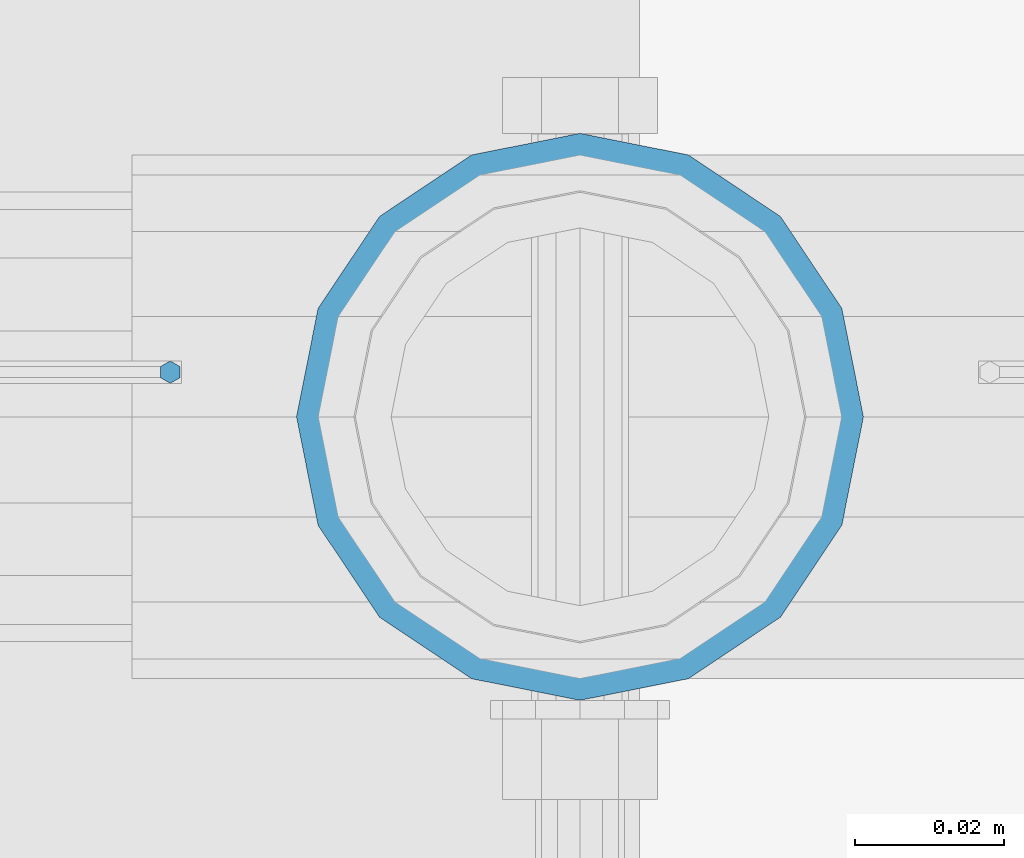
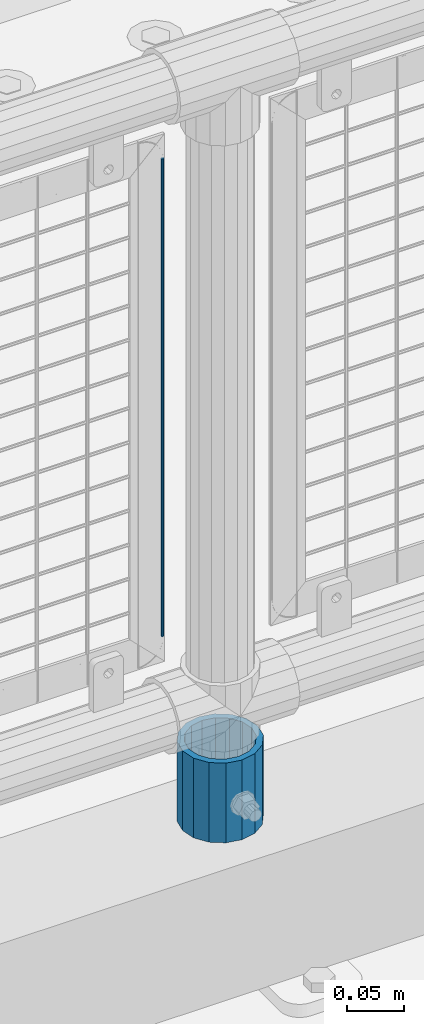
# One storey, part 90 of 242: 2 columns.
"""IFC2X3 building model written with IfcOpenShell, lengths in millimetres."""

from ifc_helpers import new_model, si_unit, frame, origin_with_axes, place, context, subcontext, project, spatial, faceted_brep, material, type_object, element, save


model = new_model("IFC2X3")

# Units and contexts
model_context = context("Model", 3, precision=1e-05, world=origin_with_axes())
body_context = subcontext(model_context, "Body", "Model", "MODEL_VIEW")
ifc_project = project(units=[si_unit("LENGTHUNIT", "METRE", prefix="MILLI"), si_unit("AREAUNIT", "SQUARE_METRE"), si_unit("VOLUMEUNIT", "CUBIC_METRE"), si_unit("MASSUNIT", "GRAM", prefix="KILO"), si_unit("TIMEUNIT", "SECOND"), si_unit("PLANEANGLEUNIT", "RADIAN"), si_unit("SOLIDANGLEUNIT", "STERADIAN"), si_unit("THERMODYNAMICTEMPERATUREUNIT", "DEGREE_CELSIUS"), si_unit("LUMINOUSINTENSITYUNIT", "LUMEN")], contexts=[model_context])

# Site, building, storey
site_placement = place(None, origin_with_axes())
site = spatial("IfcSite", under=ifc_project, at=site_placement, CompositionType="ELEMENT")
building_placement = place(site_placement, origin_with_axes())
building = spatial("IfcBuilding", under=site, at=building_placement, Name="Standard", CompositionType="ELEMENT")
storey_placement = place(building_placement, origin_with_axes())
storey = spatial("IfcBuildingStorey", under=building, at=storey_placement, Name="Undefined", CompositionType="ELEMENT", Elevation=0.0)

# Columns
ifc_material_1 = material(Name="Misc_Undefined")
column_type_1 = type_object("IfcColumnType", Name="D3", PredefinedType="NOTDEFINED")
column_1_placement = place(storey_placement, frame((-30453.0, -19329.5, 378.02), z_axis=(-1.0, 0.0, 0.0), x_axis=(0.0, 0.0, 1.0)))
element("IfcColumn", 1, at=column_1_placement, inside=storey, type_object=column_type_1, material=ifc_material_1, ObjectType="D3", context=body_context, shape_type="Brep", body=[
    faceted_brep([(0.0, -1.50000000000364, 0.0), (-3.63797880709171e-12, -0.750000000003638, -1.29903810567669), (510.0, -0.75, -1.29903810567703), (510.0, -1.5, 0.0), (0.0, 0.749999999996362, -1.29903810567669), (510.0, 0.75, -1.29903810567703), (-3.63797880709171e-12, 1.49999999999636, 0.0), (510.0, 1.5, 0.0), (0.0, 0.749999999996362, 1.29903810567669), (510.0, 0.75, 1.29903810567703), (-3.63797880709171e-12, -0.750000000003638, 1.29903810567669), (510.0, -0.75, 1.29903810567703)], [[[0, 1, 2, 3]], [[1, 4, 5, 2]], [[4, 6, 7, 5]], [[6, 8, 9, 7]], [[8, 10, 11, 9]], [[10, 0, 3, 11]], [[5, 7, 9, 11, 3, 2]], [[10, 8, 6, 4, 1, 0]]]),
])
ifc_material_2 = material()
column_type_2 = type_object("IfcColumnType", PredefinedType="NOTDEFINED")
column_2_placement = place(storey_placement, frame((-30398.0, -19335.5, 168.02), z_axis=(0.0, 1.0, 0.0), x_axis=(0.0, 0.0, 1.0)))
element("IfcColumn", 2, at=column_2_placement, inside=storey, type_object=column_type_2, material=ifc_material_2, context=body_context, shape_type="Brep", body=[
    faceted_brep([(0.0, -31.75, 0.0), (0.0, -29.3331751572332, 12.1501989775934), (85.0, -29.3331751572332, 12.1501989775934), (85.0, -31.75, 0.0), (0.0, -22.4506403026717, 22.4506403026717), (85.0, -22.4506403026717, 22.4506403026717), (0.0, -12.1501989775934, 29.3331751572332), (85.0, -12.1501989775934, 29.3331751572332), (0.0, 0.0, 31.75), (85.0, 0.0, 31.75), (0.0, 12.1501989775934, 29.3331751572332), (85.0, 12.1501989775934, 29.3331751572332), (0.0, 22.4506403026717, 22.4506403026717), (85.0, 22.4506403026717, 22.4506403026717), (0.0, 29.3331751572332, 12.1501989775934), (85.0, 29.3331751572332, 12.1501989775934), (0.0, 31.75, 0.0), (85.0, 31.75, 0.0), (0.0, 29.3331751572332, -12.1501989775934), (85.0, 29.3331751572332, -12.1501989775934), (0.0, 22.4506403026717, -22.4506403026717), (85.0, 22.4506403026717, -22.4506403026717), (0.0, 12.1501989775934, -29.3331751572332), (85.0, 12.1501989775934, -29.3331751572332), (0.0, 0.0, -31.75), (85.0, 0.0, -31.75), (0.0, -12.1501989775934, -29.3331751572332), (85.0, -12.1501989775934, -29.3331751572332), (0.0, -22.4506403026717, -22.4506403026717), (85.0, -22.4506403026717, -22.4506403026717), (0.0, -29.3331751572332, -12.1501989775934), (85.0, -29.3331751572332, -12.1501989775934), (0.0, -38.0499999999993, 0.0), (0.0, -35.1536162120537, -14.5611046014928), (85.0, -35.1536162120537, -14.5611046014928), (85.0, -38.0499999999993, 0.0), (0.0, -26.9054130241493, -26.9054130241493), (85.0, -26.9054130241493, -26.9054130241493), (0.0, -14.5611046014928, -35.1536162120537), (85.0, -14.5611046014928, -35.1536162120537), (0.0, 0.0, -38.0499999999993), (85.0, 0.0, -38.0499999999993), (0.0, 14.5611046014928, -35.1536162120537), (85.0, 14.5611046014928, -35.1536162120537), (0.0, 26.9054130241493, -26.9054130241493), (85.0, 26.9054130241493, -26.9054130241493), (0.0, 35.1536162120537, -14.5611046014928), (85.0, 35.1536162120537, -14.5611046014928), (0.0, 38.0499999999993, 0.0), (85.0, 38.0499999999993, 0.0), (0.0, 35.1536162120537, 14.5611046014928), (85.0, 35.1536162120537, 14.5611046014928), (0.0, 26.9054130241493, 26.9054130241493), (85.0, 26.9054130241493, 26.9054130241493), (0.0, 14.5611046014928, 35.1536162120537), (85.0, 14.5611046014928, 35.1536162120537), (0.0, 0.0, 38.0499999999993), (85.0, 0.0, 38.0499999999993), (0.0, -14.5611046014928, 35.1536162120537), (85.0, -14.5611046014928, 35.1536162120537), (0.0, -26.9054130241493, 26.9054130241493), (85.0, -26.9054130241493, 26.9054130241493), (0.0, -35.1536162120537, 14.5611046014928), (85.0, -35.1536162120537, 14.5611046014928)], [[[0, 1, 2, 3]], [[1, 4, 5, 2]], [[4, 6, 7, 5]], [[6, 8, 9, 7]], [[8, 10, 11, 9]], [[10, 12, 13, 11]], [[12, 14, 15, 13]], [[14, 16, 17, 15]], [[16, 18, 19, 17]], [[18, 20, 21, 19]], [[20, 22, 23, 21]], [[22, 24, 25, 23]], [[24, 26, 27, 25]], [[26, 28, 29, 27]], [[28, 30, 31, 29]], [[30, 0, 3, 31]], [[32, 33, 34, 35]], [[33, 36, 37, 34]], [[36, 38, 39, 37]], [[38, 40, 41, 39]], [[40, 42, 43, 41]], [[42, 44, 45, 43]], [[44, 46, 47, 45]], [[46, 48, 49, 47]], [[48, 50, 51, 49]], [[50, 52, 53, 51]], [[52, 54, 55, 53]], [[54, 56, 57, 55]], [[56, 58, 59, 57]], [[58, 60, 61, 59]], [[60, 62, 63, 61]], [[62, 32, 35, 63]], [[37, 39, 41, 43, 45, 47, 49, 51, 53, 55, 57, 59, 61, 63, 35, 34], [5, 7, 9, 11, 13, 15, 17, 19, 21, 23, 25, 27, 29, 31, 3, 2]], [[62, 60, 58, 56, 54, 52, 50, 48, 46, 44, 42, 40, 38, 36, 33, 32], [30, 28, 26, 24, 22, 20, 18, 16, 14, 12, 10, 8, 6, 4, 1, 0]]]),
])

save(model, "model.ifc")
